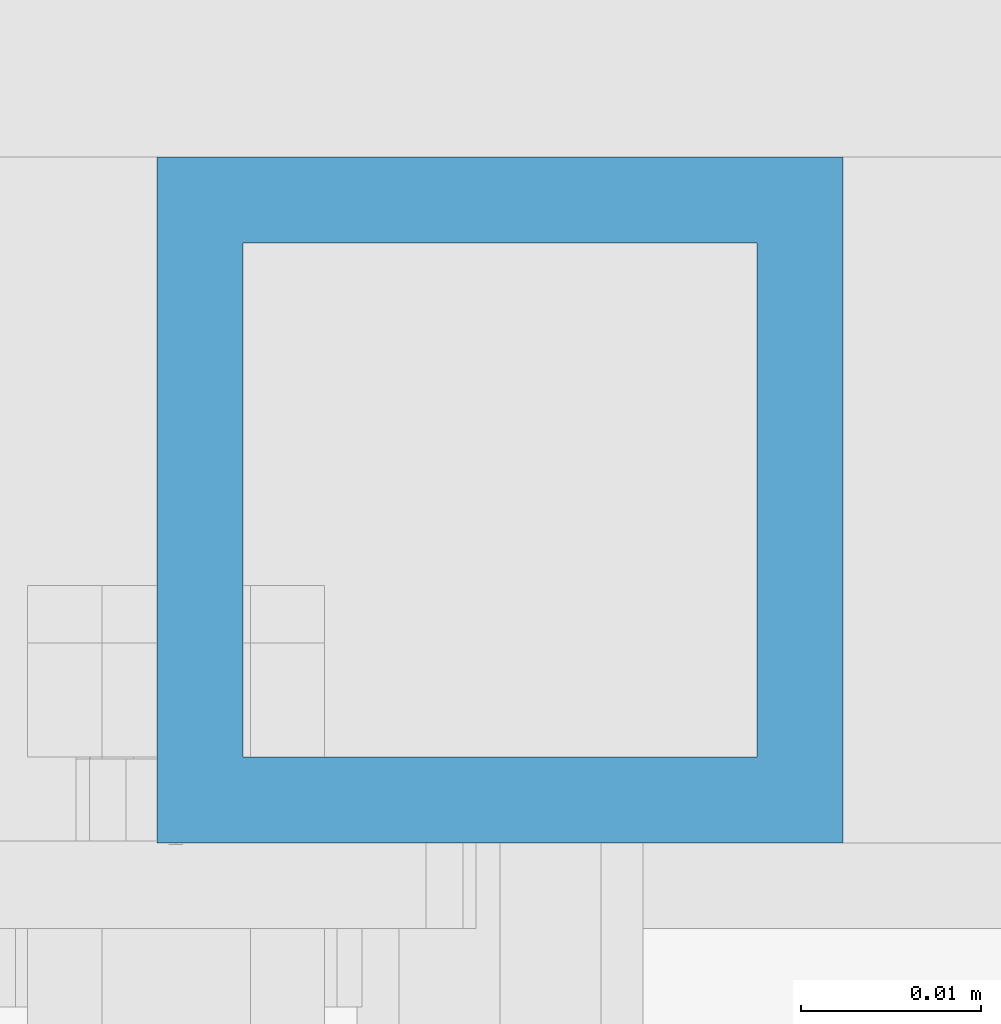
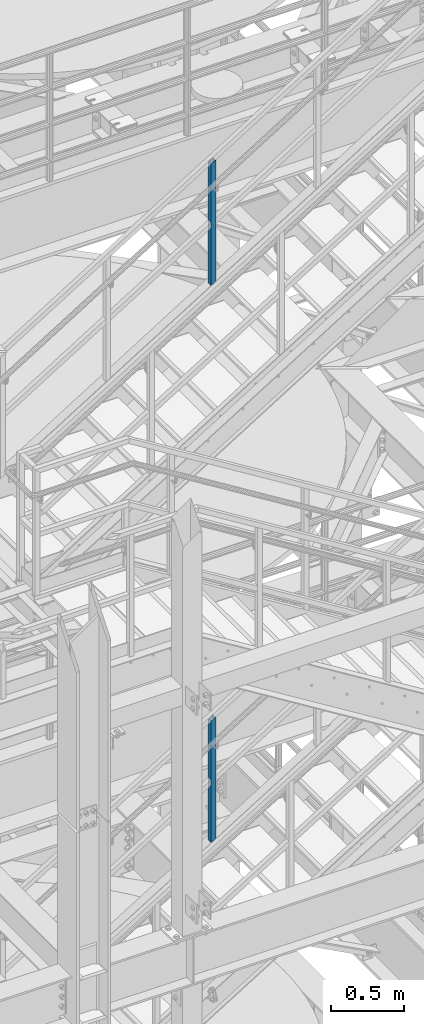
# One storey, part 633 of 1876: 2 columns, 2 elements without a shape of their own.
"""IFC2X3 building model written with IfcOpenShell, lengths in millimetres."""

from ifc_helpers import new_model, si_unit, frame, origin_with_axes, place, context, subcontext, project, spatial, faceted_brep, material, type_object, element, aggregate, save


model = new_model("IFC2X3")

# Units and contexts
model_context = context("Model", 3, precision=1e-05, world=origin_with_axes())
body_context = subcontext(model_context, "Body", "Model", "MODEL_VIEW")
ifc_project = project(units=[si_unit("LENGTHUNIT", "METRE", prefix="MILLI"), si_unit("AREAUNIT", "SQUARE_METRE"), si_unit("VOLUMEUNIT", "CUBIC_METRE"), si_unit("MASSUNIT", "GRAM", prefix="KILO"), si_unit("TIMEUNIT", "SECOND"), si_unit("PLANEANGLEUNIT", "RADIAN"), si_unit("SOLIDANGLEUNIT", "STERADIAN"), si_unit("THERMODYNAMICTEMPERATUREUNIT", "DEGREE_CELSIUS"), si_unit("LUMINOUSINTENSITYUNIT", "LUMEN")], contexts=[model_context])

# Site, building, storey
site_placement = place(None, origin_with_axes())
site = spatial("IfcSite", under=ifc_project, at=site_placement, CompositionType="ELEMENT")
building_placement = place(site_placement, origin_with_axes())
building = spatial("IfcBuilding", under=site, at=building_placement, Name="Undefined", CompositionType="ELEMENT")
storey_placement = place(building_placement, origin_with_axes())
storey = spatial("IfcBuildingStorey", under=building, at=storey_placement, Name="Undefined", CompositionType="ELEMENT", Elevation=0.0)

# Assembly, column
assembly_1_placement = place(storey_placement, origin_with_axes())
assembly_1 = element("IfcElementAssembly", 1, at=assembly_1_placement, inside=storey, Name="RAIL", AssemblyPlace="NOTDEFINED", PredefinedType="RIGID_FRAME")
ifc_material = material()
column_type = type_object("IfcColumnType", Name="HSS1-1/2X1-1/2X3/16", PredefinedType="NOTDEFINED")
column_1_placement = place(assembly_1_placement, frame((4085.1666667741, -4781.55000114554, 12111.9788924859), z_axis=(-1.0, 0.0, 0.0), x_axis=(0.0, 0.0, 1.0)))
column_1 = element("IfcColumn", 2, at=column_1_placement, type_object=column_type, material=ifc_material, Name="POST", ObjectType="HSS1-1/2X1-1/2X3/16", context=body_context, shape_type="Brep", body=[
    faceted_brep([(1026.33175871902, -19.0500000000002, -19.0499992350001), (1026.33175871902, 19.0499992349996, -19.0499992350001), (1002.89450115962, 19.0499992349996, 19.0499992349996), (1002.89450115962, -19.0499992349996, 19.0499992349996), (1023.40208377724, -14.2874994260001, -14.2874994260001), (1005.82416013402, -14.2874994260001, 14.2874994260001), (1005.82416013402, 14.2874994260001, 14.2874994260001), (1023.40208377724, 14.2874994260001, -14.2874994260001), (-11.7186358969739, 19.0499992349996, 19.0499992349996), (-11.7186358969739, -19.0499992349996, 19.0499992349996), (11.7186358969793, -19.0499992349996, -19.0499992349996), (11.7186358969793, 19.0499992349996, -19.0499992349996), (-8.78902482466219, 14.2874994260001, 14.2874994260001), (-8.78902482466219, -14.2874994260001, 14.2874994260001), (8.78902482575359, -14.2874994260001, -14.2874994260001), (8.78902482575359, 14.2874994260001, -14.2874994260001)], [[[0, 1, 2, 3], [4, 5, 6, 7]], [[8, 9, 3, 2]], [[9, 10, 0, 3]], [[10, 11, 1, 0]], [[11, 8, 2, 1]], [[10, 9, 8, 11], [12, 13, 14, 15]], [[15, 14, 4, 7]], [[12, 15, 7, 6]], [[13, 12, 6, 5]], [[14, 13, 5, 4]]]),
])
aggregate(assembly_1, [column_1])

assembly_2_placement = place(storey_placement, origin_with_axes())
assembly_2 = element("IfcElementAssembly", 3, at=assembly_2_placement, inside=storey, Name="RAIL", AssemblyPlace="NOTDEFINED", PredefinedType="RIGID_FRAME")
column_2_placement = place(assembly_2_placement, frame((4085.16666479088, -4781.55000114554, 16776.9100645924), z_axis=(-1.0, 0.0, 0.0), x_axis=(0.0, 0.0, 1.0)))
column_2 = element("IfcColumn", 4, at=column_2_placement, type_object=column_type, material=ifc_material, Name="POST", ObjectType="HSS1-1/2X1-1/2X3/16", context=body_context, shape_type="Brep", body=[
    faceted_brep([(1026.31311450052, -19.0500000000002, -19.0499992349996), (1026.31311450052, 19.0499992349996, -19.0499992349996), (1002.71048974224, 19.0499992349996, 19.0499992349996), (1002.71048974224, -19.0499992349996, 19.0499992349996), (1023.36278640575, -14.2874994260001, -14.2874994260001), (1005.66081783739, -14.2874994260001, 14.2874994260001), (1005.66081783739, 14.2874994260001, 14.2874994260001), (1023.36278640575, 14.2874994260001, -14.2874994260001), (-11.8013123776254, 19.0499992349996, 19.0499992349996), (-11.8013123776254, -19.0499992349996, 19.0499992349996), (11.8013123805795, -19.0499992349996, -19.0499992349996), (11.8013123805795, 19.0499992349996, -19.0499992349996), (-8.85098428269339, 14.2874994260001, 14.2874994260001), (-8.85098428269339, -14.2874994260001, 14.2874994260001), (8.85098428565107, -14.2874994260001, -14.2874994260001), (8.85098428565107, 14.2874994260001, -14.2874994260001)], [[[0, 1, 2, 3], [4, 5, 6, 7]], [[8, 9, 3, 2]], [[9, 10, 0, 3]], [[10, 11, 1, 0]], [[11, 8, 2, 1]], [[10, 9, 8, 11], [12, 13, 14, 15]], [[15, 14, 4, 7]], [[12, 15, 7, 6]], [[13, 12, 6, 5]], [[14, 13, 5, 4]]]),
])
aggregate(assembly_2, [column_2])

save(model, "model.ifc")
